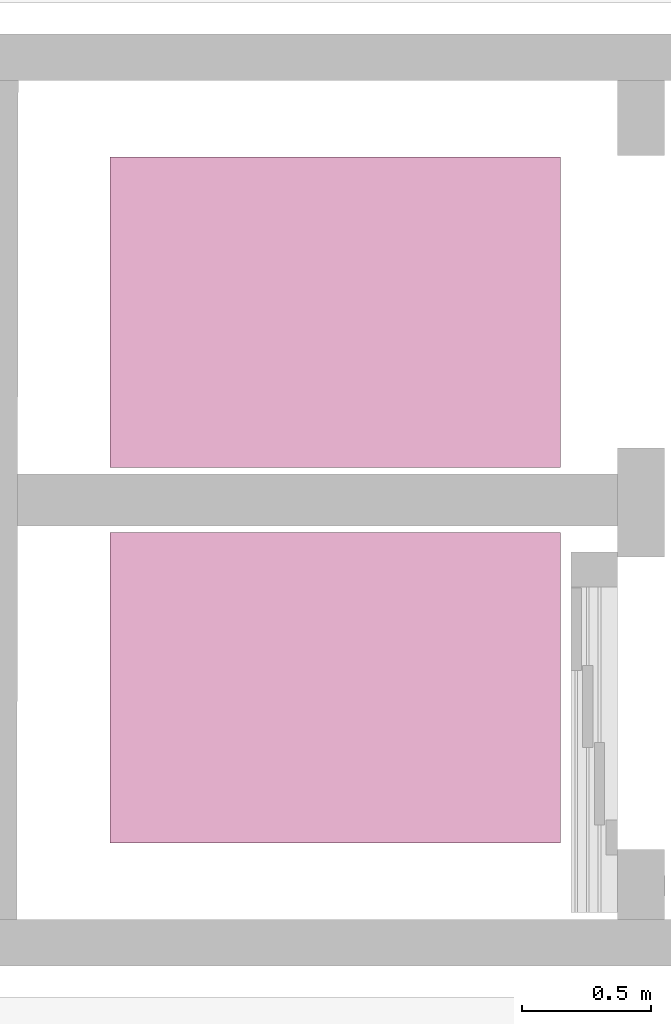
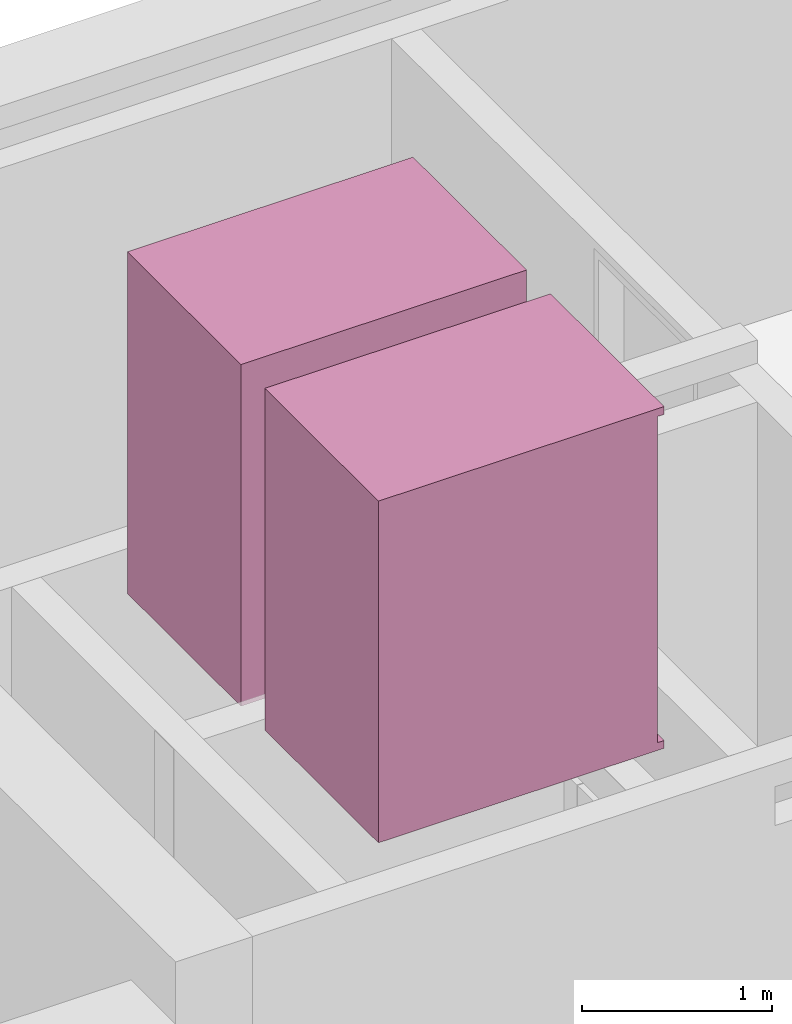
# One storey, part 5 of 5: 2 transport elements.
"""IFC4 building model written with IfcOpenShell, lengths in metres."""

from ifc_helpers import new_model, entity, si_unit, converted_unit, derived_unit, direction, frame, origin_with_axes, place, context, subcontext, project, spatial, polygons, type_object, element, save


model = new_model("IFC4")

# Units and contexts
model_context = context("Model", 3, precision=1e-05, world=origin_with_axes(), true_north=direction((0.0, 1.0)))
body_context = subcontext(model_context, "Body", "Model", "MODEL_VIEW")
ifc_project = project(units=[si_unit("LENGTHUNIT", "METRE"), si_unit("AREAUNIT", "SQUARE_METRE"), si_unit("VOLUMEUNIT", "CUBIC_METRE"), converted_unit("PLANEANGLEUNIT", "DEGREE", entity("IfcPlaneAngleMeasure", 0.0174532925199433), si_unit("PLANEANGLEUNIT", "RADIAN"), dimensions=[0, 0, 0, 0, 0, 0, 0]), converted_unit("TIMEUNIT", "Year", entity("IfcTimeMeasure", 31557600.0), si_unit("TIMEUNIT", "SECOND"), dimensions=[0, 0, 1, 0, 0, 0, 0]), si_unit("MASSUNIT", "GRAM", prefix="KILO"), si_unit("THERMODYNAMICTEMPERATUREUNIT", "DEGREE_CELSIUS"), si_unit("LUMINOUSINTENSITYUNIT", "LUMEN"), si_unit("ENERGYUNIT", "JOULE", prefix="MEGA"), derived_unit("THERMALCONDUCTANCEUNIT", [(si_unit("POWERUNIT", "WATT"), 1), (si_unit("LENGTHUNIT", "METRE"), -1), (si_unit("THERMODYNAMICTEMPERATUREUNIT", "KELVIN"), -1)]), derived_unit("SPECIFICHEATCAPACITYUNIT", [(si_unit("ENERGYUNIT", "JOULE"), 1), (si_unit("MASSUNIT", "GRAM", prefix="KILO"), -1), (si_unit("THERMODYNAMICTEMPERATUREUNIT", "KELVIN"), -1)]), derived_unit("MASSDENSITYUNIT", [(si_unit("MASSUNIT", "GRAM", prefix="KILO"), 1), (si_unit("VOLUMEUNIT", "CUBIC_METRE"), -1)])], contexts=[model_context])

# Site, building, storey, space
site_placement = place(None, origin_with_axes())
site = spatial("IfcSite", under=ifc_project, at=site_placement, CompositionType="ELEMENT")
building_placement = place(site_placement, origin_with_axes())
building = spatial("IfcBuilding", under=site, at=building_placement, CompositionType="ELEMENT")
storey_placement = place(building_placement, frame((0.0, 0.0, -3.0), z_axis=(0.0, 0.0, 1.0), x_axis=(1.0, 0.0, 0.0)))
storey = spatial("IfcBuildingStorey", under=building, at=storey_placement, Name="UG", CompositionType="ELEMENT", Elevation=-3.0)
space_1_placement = place(storey_placement, frame((29.14331793003495, 10.47499994546756, 0.0), z_axis=(0.0, 0.0, 1.0), x_axis=(-0.001641334219673784, -0.9999986530100825, 0.0)))
space_1 = spatial("IfcSpace", under=storey, at=space_1_placement, CompositionType="ELEMENT", PredefinedType="NOTDEFINED")

# Transport element
transport_element_type = type_object("IfcTransportElementType", Name="Aufzug 27", PredefinedType="ELEVATOR")
transport_element_1_placement = place(space_1_placement, frame((0.1162499114987039, 2.284875952627708, 0.0), z_axis=(0.0, 0.0, 1.0), x_axis=(-0.9999986530100825, -0.001641334219673723, 0.0)))
element("IfcTransportElement", 1, at=transport_element_1_placement, inside=space_1, type_object=transport_element_type, Name="0001", PredefinedType="ELEVATOR", context=body_context, shape_type="Tessellation", body=[
    polygons([(-0.7749999999999999, 0.21, 3.0), (-0.7749999999999999, 0.2100000000000002, 5.1), (-0.4423333333333332, 0.2100000000000002, 5.1), (-0.4423333333333332, 0.21, 3.0), (-0.7749999999999999, 0.19, 3.0), (-0.7749999999999999, 0.1900000000000001, 5.1), (-0.4423333333333332, 0.1900000000000001, 5.1), (-0.4423333333333332, 0.19, 3.0)], [[[1, 2, 3, 4]], [[1, 5, 6, 2]], [[2, 6, 7, 3]], [[3, 7, 8, 4]], [[4, 8, 5, 1]], [[8, 7, 6, 5]]], closed=True),
    polygons([(-1.107666666666667, 0.23, 3.0), (-1.107666666666667, 0.2300000000000001, 5.1), (-0.775, 0.2300000000000001, 5.1), (-0.775, 0.23, 3.0), (-1.107666666666667, 0.21, 3.0), (-1.107666666666667, 0.2100000000000001, 5.1), (-0.775, 0.2100000000000001, 5.1), (-0.775, 0.21, 3.0)], [[[1, 2, 3, 4]], [[1, 5, 6, 2]], [[2, 6, 7, 3]], [[3, 7, 8, 4]], [[4, 8, 5, 1]], [[8, 7, 6, 5]]], closed=True),
    polygons([(-0.2559999999999999, 0.27, 5.1), (-0.4423333333333333, 0.27, 5.1), (-0.4423333333333333, 0.2300000000000002, 5.1), (-0.1759999999999999, 0.2300000000000002, 5.1), (-0.1759999999999999, 1.93, 5.1), (-1.374, 1.93, 5.1), (-1.374, 0.1899999999999999, 5.1), (-1.107666666666667, 0.1899999999999999, 5.1), (-1.107666666666667, 0.27, 5.1), (-1.294, 0.27, 5.1), (-1.294, 1.85, 5.1), (-0.2559999999999999, 1.85, 5.1), (-0.2559999999999999, 0.27, 3.0), (-0.4423333333333333, 0.27, 3.0), (-0.4423333333333333, 0.23, 3.0), (-0.1759999999999999, 0.23, 3.0), (-0.1759999999999999, 1.93, 3.0), (-1.374, 1.93, 3.0), (-1.374, 0.1899999999999999, 3.0), (-1.107666666666667, 0.1899999999999999, 3.0), (-1.107666666666667, 0.27, 3.0), (-1.294, 0.27, 3.0), (-1.294, 1.85, 3.0), (-0.2559999999999999, 1.85, 3.0)], [[[1, 2, 3, 4, 5, 6, 7, 8, 9, 10, 11, 12]], [[1, 13, 14, 2]], [[14, 15, 3, 2]], [[3, 15, 16, 4]], [[5, 4, 16, 17]], [[6, 5, 17, 18]], [[7, 6, 18, 19]], [[20, 8, 7, 19]], [[9, 8, 20, 21]], [[9, 21, 22, 10]], [[10, 22, 23, 11]], [[11, 23, 24, 12]], [[12, 24, 13, 1]], [[13, 24, 23, 22, 21, 20, 19, 18, 17, 16, 15, 14]]], closed=True),
    polygons([(-0.1759999999999999, 0.19, 2.95), (-0.1759999999999999, 0.19, 3.0), (-1.374, 0.19, 3.0), (-1.374, 0.19, 2.95), (-0.1759999999999999, 1.93, 2.95), (-0.1759999999999999, 1.93, 3.0), (-1.374, 1.93, 3.0), (-1.374, 1.93, 2.95)], [[[1, 2, 3, 4]], [[5, 6, 2, 1]], [[2, 6, 7, 3]], [[4, 3, 7, 8]], [[1, 4, 8, 5]], [[8, 7, 6, 5]]], closed=True),
    polygons([(-0.1759999999999999, 0.19, 5.1), (-0.1759999999999999, 0.19, 5.149999999999999), (-1.374, 0.19, 5.149999999999999), (-1.374, 0.19, 5.1), (-0.1759999999999999, 1.93, 5.1), (-0.1759999999999999, 1.93, 5.149999999999999), (-1.374, 1.93, 5.149999999999999), (-1.374, 1.93, 5.1)], [[[1, 2, 3, 4]], [[5, 6, 2, 1]], [[2, 6, 7, 3]], [[4, 3, 7, 8]], [[1, 4, 8, 5]], [[8, 7, 6, 5]]], closed=True),
    polygons([(-1.294, 0.37, 4.0), (-1.294, 0.37, 4.15), (-1.294, 0.47, 4.15), (-1.294, 0.47, 4.0), (-1.284, 0.37, 4.0), (-1.284, 0.37, 4.15), (-1.284, 0.47, 4.15), (-1.284, 0.47, 4.0)], [[[1, 2, 3, 4]], [[1, 5, 6, 2]], [[2, 6, 7, 3]], [[3, 7, 8, 4]], [[4, 8, 5, 1]], [[8, 7, 6, 5]]], closed=True),
    polygons([(-1.284, 0.4504289321881346, 4.005428932188135), (-1.279, 0.4518431457505077, 4.006843145750508), (-1.279, 0.4518431457505077, 4.018156854249493), (-1.284, 0.4504289321881346, 4.019571067811865), (-1.284, 0.4645710678118655, 4.005428932188135), (-1.279, 0.4631568542494924, 4.006843145750508), (-1.279, 0.4631568542494924, 4.018156854249493), (-1.284, 0.4645710678118655, 4.019571067811865)], [[[1, 2, 3, 4]], [[5, 6, 2, 1]], [[2, 6, 7, 3]], [[4, 3, 7, 8]], [[1, 4, 8, 5]], [[8, 7, 6, 5]]], closed=True),
    polygons([(-1.284, 0.4254289321881345, 4.005428932188135), (-1.279, 0.4268431457505076, 4.006843145750508), (-1.279, 0.4268431457505076, 4.018156854249493), (-1.284, 0.4254289321881345, 4.019571067811865), (-1.284, 0.4395710678118654, 4.005428932188135), (-1.279, 0.4381568542494924, 4.006843145750508), (-1.279, 0.4381568542494924, 4.018156854249493), (-1.284, 0.4395710678118654, 4.019571067811865)], [[[1, 2, 3, 4]], [[5, 6, 2, 1]], [[2, 6, 7, 3]], [[4, 3, 7, 8]], [[1, 4, 8, 5]], [[8, 7, 6, 5]]], closed=True),
    polygons([(-1.284, 0.4004289321881346, 4.005428932188135), (-1.279, 0.4018431457505077, 4.006843145750508), (-1.279, 0.4018431457505077, 4.018156854249493), (-1.284, 0.4004289321881346, 4.019571067811865), (-1.284, 0.4145710678118655, 4.005428932188135), (-1.279, 0.4131568542494924, 4.006843145750508), (-1.279, 0.4131568542494924, 4.018156854249493), (-1.284, 0.4145710678118655, 4.019571067811865)], [[[1, 2, 3, 4]], [[5, 6, 2, 1]], [[2, 6, 7, 3]], [[4, 3, 7, 8]], [[1, 4, 8, 5]], [[8, 7, 6, 5]]], closed=True),
    polygons([(-1.284, 0.3754289321881346, 4.005428932188135), (-1.279, 0.3768431457505076, 4.006843145750508), (-1.279, 0.3768431457505076, 4.018156854249493), (-1.284, 0.3754289321881346, 4.019571067811865), (-1.284, 0.3895710678118655, 4.005428932188135), (-1.279, 0.3881568542494924, 4.006843145750508), (-1.279, 0.3881568542494924, 4.018156854249493), (-1.284, 0.3895710678118655, 4.019571067811865)], [[[1, 2, 3, 4]], [[5, 6, 2, 1]], [[2, 6, 7, 3]], [[4, 3, 7, 8]], [[1, 4, 8, 5]], [[8, 7, 6, 5]]], closed=True),
    polygons([(-1.284, 0.4504289321881346, 4.130428932188135), (-1.279, 0.4518431457505077, 4.131843145750508), (-1.279, 0.4518431457505077, 4.143156854249493), (-1.284, 0.4504289321881346, 4.144571067811865), (-1.284, 0.4645710678118655, 4.130428932188135), (-1.279, 0.4631568542494924, 4.131843145750508), (-1.279, 0.4631568542494924, 4.143156854249493), (-1.284, 0.4645710678118655, 4.144571067811865)], [[[1, 2, 3, 4]], [[5, 6, 2, 1]], [[2, 6, 7, 3]], [[4, 3, 7, 8]], [[1, 4, 8, 5]], [[8, 7, 6, 5]]], closed=True),
    polygons([(-1.284, 0.4504289321881346, 4.105428932188135), (-1.279, 0.4518431457505077, 4.106843145750507), (-1.279, 0.4518431457505077, 4.118156854249492), (-1.284, 0.4504289321881346, 4.119571067811865), (-1.284, 0.4645710678118655, 4.105428932188135), (-1.279, 0.4631568542494924, 4.106843145750507), (-1.279, 0.4631568542494924, 4.118156854249492), (-1.284, 0.4645710678118655, 4.119571067811865)], [[[1, 2, 3, 4]], [[5, 6, 2, 1]], [[2, 6, 7, 3]], [[4, 3, 7, 8]], [[1, 4, 8, 5]], [[8, 7, 6, 5]]], closed=True),
    polygons([(-1.284, 0.4504289321881346, 4.080428932188135), (-1.279, 0.4518431457505077, 4.081843145750508), (-1.279, 0.4518431457505077, 4.093156854249493), (-1.284, 0.4504289321881346, 4.094571067811866), (-1.284, 0.4645710678118655, 4.080428932188135), (-1.279, 0.4631568542494924, 4.081843145750508), (-1.279, 0.4631568542494924, 4.093156854249493), (-1.284, 0.4645710678118655, 4.094571067811866)], [[[1, 2, 3, 4]], [[5, 6, 2, 1]], [[2, 6, 7, 3]], [[4, 3, 7, 8]], [[1, 4, 8, 5]], [[8, 7, 6, 5]]], closed=True),
    polygons([(-1.284, 0.4504289321881346, 4.055428932188135), (-1.279, 0.4518431457505077, 4.056843145750507), (-1.279, 0.4518431457505077, 4.068156854249493), (-1.284, 0.4504289321881346, 4.069571067811865), (-1.284, 0.4645710678118655, 4.055428932188135), (-1.279, 0.4631568542494924, 4.056843145750507), (-1.279, 0.4631568542494924, 4.068156854249493), (-1.284, 0.4645710678118655, 4.069571067811865)], [[[1, 2, 3, 4]], [[5, 6, 2, 1]], [[2, 6, 7, 3]], [[4, 3, 7, 8]], [[1, 4, 8, 5]], [[8, 7, 6, 5]]], closed=True),
])

# Space
space_2_placement = place(storey_placement, frame((29.14049483137442, 8.754999945467555, 0.0), z_axis=(0.0, 0.0, 1.0), x_axis=(-0.001641334219673783, -0.9999986530100825, 0.0)))
space_2 = spatial("IfcSpace", under=storey, at=space_2_placement, CompositionType="ELEMENT", PredefinedType="NOTDEFINED")

# Transport element
transport_element_2_placement = place(space_2_placement, frame((1.396243553703171, 2.289799955286728, 0.0), z_axis=(0.0, 0.0, 1.0), x_axis=(-0.9999986530100825, -0.001641334219673722, 0.0)))
element("IfcTransportElement", 2, at=transport_element_2_placement, inside=space_2, type_object=transport_element_type, Name="0001", PredefinedType="ELEVATOR", context=body_context, shape_type="Tessellation", body=[
    polygons([(0.7749999999999999, 0.21, 3.0), (0.4423333333333332, 0.21, 3.0), (0.4423333333333332, 0.2100000000000002, 5.1), (0.7749999999999999, 0.2100000000000002, 5.1), (0.7749999999999999, 0.19, 3.0), (0.4423333333333332, 0.19, 3.0), (0.4423333333333332, 0.1900000000000001, 5.1), (0.7749999999999999, 0.1900000000000001, 5.1)], [[[1, 2, 3, 4]], [[2, 1, 5, 6]], [[3, 2, 6, 7]], [[4, 3, 7, 8]], [[1, 4, 8, 5]], [[6, 5, 8, 7]]], closed=True),
    polygons([(1.107666666666667, 0.23, 3.0), (0.775, 0.23, 3.0), (0.775, 0.2300000000000001, 5.1), (1.107666666666667, 0.2300000000000001, 5.1), (1.107666666666667, 0.21, 3.0), (0.775, 0.21, 3.0), (0.775, 0.2100000000000001, 5.1), (1.107666666666667, 0.2100000000000001, 5.1)], [[[1, 2, 3, 4]], [[2, 1, 5, 6]], [[3, 2, 6, 7]], [[4, 3, 7, 8]], [[1, 4, 8, 5]], [[6, 5, 8, 7]]], closed=True),
    polygons([(0.2559999999999999, 0.27, 5.1), (0.2559999999999999, 1.85, 5.1), (1.294, 1.85, 5.1), (1.294, 0.27, 5.1), (1.107666666666667, 0.27, 5.1), (1.107666666666667, 0.1899999999999999, 5.1), (1.374, 0.1899999999999999, 5.1), (1.374, 1.93, 5.1), (0.1759999999999999, 1.93, 5.1), (0.1759999999999999, 0.2300000000000002, 5.1), (0.4423333333333333, 0.2300000000000002, 5.1), (0.4423333333333333, 0.27, 5.1), (0.2559999999999999, 0.27, 3.0), (0.2559999999999999, 1.85, 3.0), (1.294, 1.85, 3.0), (1.294, 0.27, 3.0), (1.107666666666667, 0.27, 3.0), (1.107666666666667, 0.1899999999999999, 3.0), (1.374, 0.1899999999999999, 3.0), (1.374, 1.93, 3.0), (0.1759999999999999, 1.93, 3.0), (0.1759999999999999, 0.23, 3.0), (0.4423333333333333, 0.23, 3.0), (0.4423333333333333, 0.27, 3.0)], [[[1, 2, 3, 4, 5, 6, 7, 8, 9, 10, 11, 12]], [[2, 1, 13, 14]], [[3, 2, 14, 15]], [[4, 3, 15, 16]], [[5, 4, 16, 17]], [[5, 17, 18, 6]], [[18, 19, 7, 6]], [[7, 19, 20, 8]], [[8, 20, 21, 9]], [[9, 21, 22, 10]], [[11, 10, 22, 23]], [[24, 12, 11, 23]], [[1, 12, 24, 13]], [[13, 24, 23, 22, 21, 20, 19, 18, 17, 16, 15, 14]]], closed=True),
    polygons([(0.1759999999999999, 0.19, 2.95), (1.374, 0.19, 2.95), (1.374, 0.19, 3.0), (0.1759999999999999, 0.19, 3.0), (0.1759999999999999, 1.93, 2.95), (1.374, 1.93, 2.95), (1.374, 1.93, 3.0), (0.1759999999999999, 1.93, 3.0)], [[[1, 2, 3, 4]], [[1, 5, 6, 2]], [[2, 6, 7, 3]], [[4, 3, 7, 8]], [[5, 1, 4, 8]], [[6, 5, 8, 7]]], closed=True),
    polygons([(0.1759999999999999, 0.19, 5.1), (1.374, 0.19, 5.1), (1.374, 0.19, 5.149999999999999), (0.1759999999999999, 0.19, 5.149999999999999), (0.1759999999999999, 1.93, 5.1), (1.374, 1.93, 5.1), (1.374, 1.93, 5.149999999999999), (0.1759999999999999, 1.93, 5.149999999999999)], [[[1, 2, 3, 4]], [[1, 5, 6, 2]], [[2, 6, 7, 3]], [[4, 3, 7, 8]], [[5, 1, 4, 8]], [[6, 5, 8, 7]]], closed=True),
    polygons([(1.294, 0.37, 4.0), (1.294, 0.47, 4.0), (1.294, 0.47, 4.15), (1.294, 0.37, 4.15), (1.284, 0.37, 4.0), (1.284, 0.47, 4.0), (1.284, 0.47, 4.15), (1.284, 0.37, 4.15)], [[[1, 2, 3, 4]], [[2, 1, 5, 6]], [[3, 2, 6, 7]], [[4, 3, 7, 8]], [[1, 4, 8, 5]], [[6, 5, 8, 7]]], closed=True),
    polygons([(1.284, 0.4504289321881346, 4.005428932188135), (1.284, 0.4504289321881346, 4.019571067811865), (1.279, 0.4518431457505077, 4.018156854249493), (1.279, 0.4518431457505077, 4.006843145750508), (1.284, 0.4645710678118655, 4.005428932188135), (1.284, 0.4645710678118655, 4.019571067811865), (1.279, 0.4631568542494924, 4.018156854249493), (1.279, 0.4631568542494924, 4.006843145750508)], [[[1, 2, 3, 4]], [[1, 5, 6, 2]], [[2, 6, 7, 3]], [[4, 3, 7, 8]], [[5, 1, 4, 8]], [[6, 5, 8, 7]]], closed=True),
    polygons([(1.284, 0.4254289321881345, 4.005428932188135), (1.284, 0.4254289321881345, 4.019571067811865), (1.279, 0.4268431457505076, 4.018156854249493), (1.279, 0.4268431457505076, 4.006843145750508), (1.284, 0.4395710678118654, 4.005428932188135), (1.284, 0.4395710678118654, 4.019571067811865), (1.279, 0.4381568542494924, 4.018156854249493), (1.279, 0.4381568542494924, 4.006843145750508)], [[[1, 2, 3, 4]], [[1, 5, 6, 2]], [[2, 6, 7, 3]], [[4, 3, 7, 8]], [[5, 1, 4, 8]], [[6, 5, 8, 7]]], closed=True),
    polygons([(1.284, 0.4004289321881346, 4.005428932188135), (1.284, 0.4004289321881346, 4.019571067811865), (1.279, 0.4018431457505077, 4.018156854249493), (1.279, 0.4018431457505077, 4.006843145750508), (1.284, 0.4145710678118655, 4.005428932188135), (1.284, 0.4145710678118655, 4.019571067811865), (1.279, 0.4131568542494924, 4.018156854249493), (1.279, 0.4131568542494924, 4.006843145750508)], [[[1, 2, 3, 4]], [[1, 5, 6, 2]], [[2, 6, 7, 3]], [[4, 3, 7, 8]], [[5, 1, 4, 8]], [[6, 5, 8, 7]]], closed=True),
    polygons([(1.284, 0.3754289321881346, 4.005428932188135), (1.284, 0.3754289321881346, 4.019571067811865), (1.279, 0.3768431457505076, 4.018156854249493), (1.279, 0.3768431457505076, 4.006843145750508), (1.284, 0.3895710678118655, 4.005428932188135), (1.284, 0.3895710678118655, 4.019571067811865), (1.279, 0.3881568542494924, 4.018156854249493), (1.279, 0.3881568542494924, 4.006843145750508)], [[[1, 2, 3, 4]], [[1, 5, 6, 2]], [[2, 6, 7, 3]], [[4, 3, 7, 8]], [[5, 1, 4, 8]], [[6, 5, 8, 7]]], closed=True),
    polygons([(1.284, 0.4504289321881346, 4.130428932188135), (1.284, 0.4504289321881346, 4.144571067811865), (1.279, 0.4518431457505077, 4.143156854249493), (1.279, 0.4518431457505077, 4.131843145750508), (1.284, 0.4645710678118655, 4.130428932188135), (1.284, 0.4645710678118655, 4.144571067811865), (1.279, 0.4631568542494924, 4.143156854249493), (1.279, 0.4631568542494924, 4.131843145750508)], [[[1, 2, 3, 4]], [[1, 5, 6, 2]], [[2, 6, 7, 3]], [[4, 3, 7, 8]], [[5, 1, 4, 8]], [[6, 5, 8, 7]]], closed=True),
    polygons([(1.284, 0.4504289321881346, 4.105428932188135), (1.284, 0.4504289321881346, 4.119571067811865), (1.279, 0.4518431457505077, 4.118156854249492), (1.279, 0.4518431457505077, 4.106843145750507), (1.284, 0.4645710678118655, 4.105428932188135), (1.284, 0.4645710678118655, 4.119571067811865), (1.279, 0.4631568542494924, 4.118156854249492), (1.279, 0.4631568542494924, 4.106843145750507)], [[[1, 2, 3, 4]], [[1, 5, 6, 2]], [[2, 6, 7, 3]], [[4, 3, 7, 8]], [[5, 1, 4, 8]], [[6, 5, 8, 7]]], closed=True),
    polygons([(1.284, 0.4504289321881346, 4.080428932188135), (1.284, 0.4504289321881346, 4.094571067811866), (1.279, 0.4518431457505077, 4.093156854249493), (1.279, 0.4518431457505077, 4.081843145750508), (1.284, 0.4645710678118655, 4.080428932188135), (1.284, 0.4645710678118655, 4.094571067811866), (1.279, 0.4631568542494924, 4.093156854249493), (1.279, 0.4631568542494924, 4.081843145750508)], [[[1, 2, 3, 4]], [[1, 5, 6, 2]], [[2, 6, 7, 3]], [[4, 3, 7, 8]], [[5, 1, 4, 8]], [[6, 5, 8, 7]]], closed=True),
    polygons([(1.284, 0.4504289321881346, 4.055428932188135), (1.284, 0.4504289321881346, 4.069571067811865), (1.279, 0.4518431457505077, 4.068156854249493), (1.279, 0.4518431457505077, 4.056843145750507), (1.284, 0.4645710678118655, 4.055428932188135), (1.284, 0.4645710678118655, 4.069571067811865), (1.279, 0.4631568542494924, 4.068156854249493), (1.279, 0.4631568542494924, 4.056843145750507)], [[[1, 2, 3, 4]], [[1, 5, 6, 2]], [[2, 6, 7, 3]], [[4, 3, 7, 8]], [[5, 1, 4, 8]], [[6, 5, 8, 7]]], closed=True),
])

save(model, "model.ifc")
